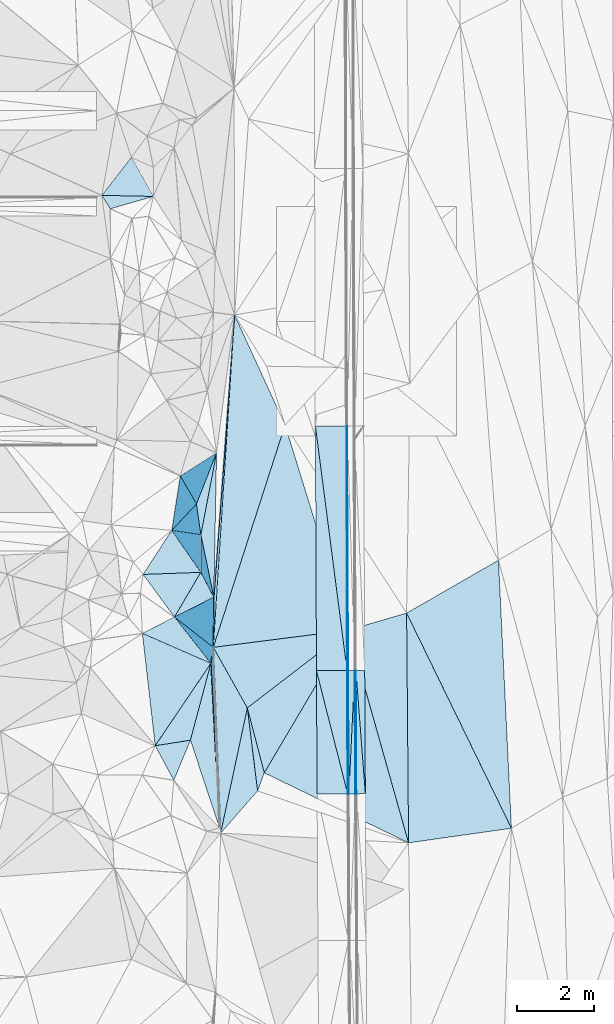
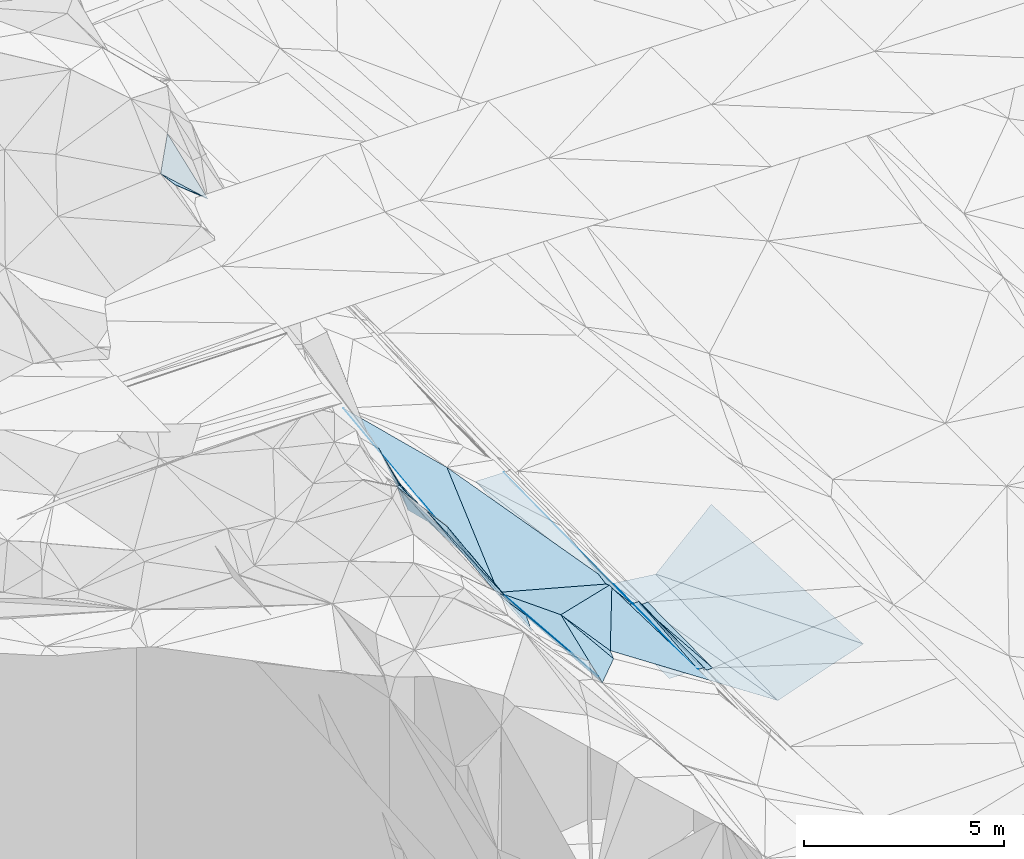
# One storey, part 63 of 275: 46 plates.
"""IFC2X3 building model written with IfcOpenShell, lengths in millimetres."""

from ifc_helpers import new_model, si_unit, frame, origin_with_axes, place, context, subcontext, project, spatial, polyline, outline, extrude, material, type_object, element, save


model = new_model("IFC2X3")

# Units and contexts
model_context = context("Model", 3, precision=1e-05, world=origin_with_axes())
body_context = subcontext(model_context, "Body", "Model", "MODEL_VIEW")
ifc_project = project(units=[si_unit("LENGTHUNIT", "METRE", prefix="MILLI"), si_unit("AREAUNIT", "SQUARE_METRE"), si_unit("VOLUMEUNIT", "CUBIC_METRE"), si_unit("MASSUNIT", "GRAM", prefix="KILO"), si_unit("TIMEUNIT", "SECOND"), si_unit("PLANEANGLEUNIT", "RADIAN"), si_unit("SOLIDANGLEUNIT", "STERADIAN"), si_unit("THERMODYNAMICTEMPERATUREUNIT", "DEGREE_CELSIUS"), si_unit("LUMINOUSINTENSITYUNIT", "LUMEN")], contexts=[model_context])

# Site, building, storey
site_placement = place(None, origin_with_axes())
site = spatial("IfcSite", under=ifc_project, at=site_placement, CompositionType="ELEMENT")
building_placement = place(site_placement, origin_with_axes())
building = spatial("IfcBuilding", under=site, at=building_placement, Name="Undefined", CompositionType="ELEMENT")
storey_placement = place(building_placement, origin_with_axes())
storey = spatial("IfcBuildingStorey", under=building, at=storey_placement, Name="Undefined", CompositionType="ELEMENT", Elevation=0.0)

# Plates
ifc_material = material()
plate_type_1 = type_object("IfcPlateType", PredefinedType="NOTDEFINED")
plate_1_placement = place(storey_placement, frame((-94041.2478735772, 50948.7305585253, 41968.9917380828), z_axis=(-0.970144857426459, -0.000212112947850965, -0.242526102960264), x_axis=(-0.0142838621161237, 0.998313705221828, 0.0562647069601703)))
element("IfcPlate", 1, at=plate_1_placement, inside=storey, type_object=plate_type_1, material=ifc_material, Name="00_PR", context=body_context, shape_type="SweptSolid", body=[
    extrude(outline(polyline([(0.0, 0.0), (3227.333984375, -1.0986695997417e-08), (3220.42529296875, 123.500061035156), (0.0, 0.0)])), frame((-8.85201319254618e-08, 2.18876761149539e-07, -0.5000001331573), z_axis=(0.0, 0.0, 1.0), x_axis=(1.0, 0.0, 0.0)), (0.0, 0.0, 1.0), 1.0),
])
plate_2_placement = place(storey_placement, frame((-94071.035261169, 50945.771579664, 42088.9925398327), z_axis=(-0.970544312702776, -0.000308208476193155, -0.240922481491106), x_axis=(-0.00505711011222381, 0.999804917063074, 0.019093282950109)))
element("IfcPlate", 2, at=plate_2_placement, inside=storey, type_object=plate_type_1, material=ifc_material, Name="00_PR", context=body_context, shape_type="SweptSolid", body=[
    extrude(outline(polyline([(0.0, 0.0), (3225.47998046875, -1.05428625829518e-08), (0.516522586345673, 123.676048278809), (0.0, 0.0)])), frame((-8.85201319254618e-08, 2.18876761149539e-07, -0.5000001331573), z_axis=(0.0, 0.0, 1.0), x_axis=(1.0, 0.0, 0.0)), (0.0, 0.0, 1.0), 1.0),
])
plate_type_2 = type_object("IfcPlateType", PredefinedType="NOTDEFINED")
plate_3_placement = place(storey_placement, frame((-94286.8693814352, 54169.6735547342, 42150.7981971723), z_axis=(-0.020087146616236, 0.0196603324347761, -0.999604910886982), x_axis=(0.000438543900374079, 0.99980671603672, 0.019655488981887)))
element("IfcPlate", 3, at=plate_3_placement, inside=storey, type_object=plate_type_2, material=ifc_material, Name="00_PR", context=body_context, shape_type="SweptSolid", body=[
    extrude(outline(polyline([(0.0, 0.0), (6386.56201171875, 4.8748916015029e-09), (0.145709604024887, 30.0053462982178), (0.0, 0.0)])), frame((-8.85201319254618e-08, 2.18876761149539e-07, -0.5000001331573), z_axis=(0.0, 0.0, 1.0), x_axis=(1.0, 0.0, 0.0)), (0.0, 0.0, 1.0), 1.0),
])
plate_4_placement = place(storey_placement, frame((-94270.5574787857, 50944.7155366074, 42089.2131909046), z_axis=(-0.0200935656827994, 0.0189875293703551, -0.999617788130324), x_axis=(0.0042432388975566, 0.99981226276399, 0.0189059289750381)))
element("IfcPlate", 4, at=plate_4_placement, inside=storey, type_object=plate_type_2, material=ifc_material, Name="00_PR", context=body_context, shape_type="SweptSolid", body=[
    extrude(outline(polyline([(0.0, 0.0), (3225.70776367188, 6.12635631114244e-09), (0.275933593511581, 30.0052528381348), (0.0, 0.0)])), frame((-8.85201319254618e-08, 2.18876761149539e-07, -0.5000001331573), z_axis=(0.0, 0.0, 1.0), x_axis=(1.0, 0.0, 0.0)), (0.0, 0.0, 1.0), 1.0),
])
plate_5_placement = place(storey_placement, frame((-94256.8700281877, 54169.817593453, 42150.1981918576), z_axis=(-0.0200835313920185, 0.0189874969806564, -0.999617990396949), x_axis=(-0.00424323889120028, -0.999812262764378, -0.0189059289559082)))
element("IfcPlate", 5, at=plate_5_placement, inside=storey, type_object=plate_type_2, material=ifc_material, Name="00_PR", context=body_context, shape_type="SweptSolid", body=[
    extrude(outline(polyline([(0.0, 0.0), (3225.70776367188, 6.12635631114244e-09), (0.260298550128937, 30.0045719146729), (0.0, 0.0)])), frame((-8.85201319254618e-08, 2.18876761149539e-07, -0.5000001331573), z_axis=(0.0, 0.0, 1.0), x_axis=(1.0, 0.0, 0.0)), (0.0, 0.0, 1.0), 1.0),
])
plate_type_3 = type_object("IfcPlateType", PredefinedType="NOTDEFINED")
plate_6_placement = place(storey_placement, frame((-95086.8597378606, 54165.8420910092, 42166.7981906724), z_axis=(-0.0200835313920185, 0.0189874969806564, -0.999617990396949), x_axis=(0.999788595128482, 0.00478795512433711, -0.0199960130211749)))
element("IfcPlate", 6, at=plate_6_placement, inside=storey, type_object=plate_type_3, material=ifc_material, Name="00_PR", context=body_context, shape_type="SweptSolid", body=[
    extrude(outline(polyline([(0.0, 0.0), (800.159484863281, -4.0818122215569e-09), (802.258483886719, 3225.58618164063), (0.0, 0.0)])), frame((-8.85201319254618e-08, 2.18876761149539e-07, -0.5000001331573), z_axis=(0.0, 0.0, 1.0), x_axis=(1.0, 0.0, 0.0)), (0.0, 0.0, 1.0), 1.0),
])
plate_7_placement = place(storey_placement, frame((-95114.0626587385, 60551.9062229557, 42292.9291968387), z_axis=(-0.020065563650007, 0.019660330856377, -0.99960534439649), x_axis=(0.99979310769204, 0.00372851110529092, -0.0199960000107533)))
element("IfcPlate", 7, at=plate_7_placement, inside=storey, type_object=plate_type_3, material=ifc_material, Name="00_PR", context=body_context, shape_type="SweptSolid", body=[
    extrude(outline(polyline([(0.0, 0.0), (800.160034179688, -7.8580342233181e-10), (806.067993164063, 6386.51708984375), (0.0, 0.0)])), frame((-8.85201319254618e-08, 2.18876761149539e-07, -0.5000001331573), z_axis=(0.0, 0.0, 1.0), x_axis=(1.0, 0.0, 0.0)), (0.0, 0.0, 1.0), 1.0),
])
plate_8_placement = place(storey_placement, frame((-94286.8693814352, 54169.6735547342, 42150.7981971723), z_axis=(-0.0200864802887268, 0.0196576115205439, -0.999604977788185), x_axis=(-0.999788595128673, -0.00478795510259425, 0.0199960130168507)))
element("IfcPlate", 8, at=plate_8_placement, inside=storey, type_object=plate_type_3, material=ifc_material, Name="00_PR", context=body_context, shape_type="SweptSolid", body=[
    extrude(outline(polyline([(0.0, 0.0), (800.159484863281, -4.0818122215569e-09), (799.302612304688, 6387.3671875), (0.0, 0.0)])), frame((-8.85201319254618e-08, 2.18876761149539e-07, -0.5000001331573), z_axis=(0.0, 0.0, 1.0), x_axis=(1.0, 0.0, 0.0)), (0.0, 0.0, 1.0), 1.0),
])
plate_9_placement = place(storey_placement, frame((-94270.5574787857, 50944.7155366074, 42089.2131909046), z_axis=(-0.0200937685935503, 0.018984898210887, -0.9996178340264), x_axis=(-0.99978587787653, -0.00532522509258222, 0.0199960090110697)))
element("IfcPlate", 9, at=plate_9_placement, inside=storey, type_object=plate_type_3, material=ifc_material, Name="00_PR", context=body_context, shape_type="SweptSolid", body=[
    extrude(outline(polyline([(0.0, 0.0), (800.15966796875, 1.0113581083715e-09), (800.525634765625, 3226.0166015625), (0.0, 0.0)])), frame((-8.85201319254618e-08, 2.18876761149539e-07, -0.5000001331573), z_axis=(0.0, 0.0, 1.0), x_axis=(1.0, 0.0, 0.0)), (0.0, 0.0, 1.0), 1.0),
])
plate_type_4 = type_object("IfcPlateType", PredefinedType="NOTDEFINED")
plate_10_placement = place(storey_placement, frame((-94056.84665461, 54170.9040629305, 42030.1983585212), z_axis=(0.0325038050928292, 0.0193184689417992, -0.999284894017833), x_axis=(0.999459808725716, 0.00423071511506999, 0.0325912839816308)))
element("IfcPlate", 10, at=plate_10_placement, inside=storey, type_object=plate_type_4, material=ifc_material, Name="00_PR", context=body_context, shape_type="SweptSolid", body=[
    extrude(outline(polyline([(0.0, 0.0), (230.12287902832, -1.17870513349772e-09), (230.761566162109, 3213.30981445313), (0.0, 0.0)])), frame((-8.85201319254618e-08, 2.18876761149539e-07, -0.5000001331573), z_axis=(0.0, 0.0, 1.0), x_axis=(1.0, 0.0, 0.0)), (0.0, 0.0, 1.0), 1.0),
])
plate_11_placement = place(storey_placement, frame((-94056.8470525321, 54170.9040306075, 42030.1983445947), z_axis=(0.0317122800381576, 0.0192582290780445, -0.999311488930033), x_axis=(0.0764359521383084, -0.996933172121253, -0.0167867669599003)))
element("IfcPlate", 11, at=plate_11_placement, inside=storey, type_object=plate_type_4, material=ifc_material, Name="00_PR", context=body_context, shape_type="SweptSolid", body=[
    extrude(outline(polyline([(0.0, 0.0), (3221.58520507813, -6.18456397205591e-09), (3214.54638671875, 230.397048950195), (0.0, 0.0)])), frame((-8.85201319254618e-08, 2.18876761149539e-07, -0.5000001331573), z_axis=(0.0, 0.0, 1.0), x_axis=(1.0, 0.0, 0.0)), (0.0, 0.0, 1.0), 1.0),
])
plate_type_5 = type_object("IfcPlateType", PredefinedType="NOTDEFINED")
plate_12_placement = place(storey_placement, frame((-94240.5473874211, 50944.8755996114, 42088.6130914289), z_axis=(-9.14532402907773e-05, 0.0190925236186178, -0.999817716975538), x_axis=(-0.00505711011222381, 0.999804917063074, 0.019093282950109)))
element("IfcPlate", 12, at=plate_12_placement, inside=storey, type_object=plate_type_5, material=ifc_material, Name="00_PR", context=body_context, shape_type="SweptSolid", body=[
    extrude(outline(polyline([(0.0, 0.0), (3225.5712890625, 6.81029632687569e-09), (3225.52563476563, 170.000335693359), (0.0, 0.0)])), frame((-8.85201319254618e-08, 2.18876761149539e-07, -0.5000001331573), z_axis=(0.0, 0.0, 1.0), x_axis=(1.0, 0.0, 0.0)), (0.0, 0.0, 1.0), 1.0),
])
plate_13_placement = place(storey_placement, frame((-94086.861647268, 54170.6319423128, 42150.1980923486), z_axis=(-0.000101724851935278, 0.0190939669352112, -0.99981768842061), x_axis=(0.00505711010990044, -0.999804917062819, -0.0190932829640522)))
element("IfcPlate", 13, at=plate_13_placement, inside=storey, type_object=plate_type_5, material=ifc_material, Name="00_PR", context=body_context, shape_type="SweptSolid", body=[
    extrude(outline(polyline([(0.0, 0.0), (3225.47998046875, -1.05428625829518e-08), (3225.52563476563, 169.999755859375), (0.0, 0.0)])), frame((-8.85201319254618e-08, 2.18876761149539e-07, -0.5000001331573), z_axis=(0.0, 0.0, 1.0), x_axis=(1.0, 0.0, 0.0)), (0.0, 0.0, 1.0), 1.0),
])
plate_type_6 = type_object("IfcPlateType", PredefinedType="NOTDEFINED")
plate_14_placement = place(storey_placement, frame((-97619.1957707841, 50063.499972178, 43599.6789144039), z_axis=(-0.764987449668679, -0.0492397289156156, -0.642160144314272), x_axis=(-0.301722386218934, 0.908287838968304, 0.289787513941925)))
element("IfcPlate", 14, at=plate_14_placement, inside=storey, type_object=plate_type_6, material=ifc_material, Name="00", context=body_context, shape_type="SweptSolid", body=[
    extrude(outline(polyline([(0.0, 0.0), (2519.08715820313, 9.29867383092642e-09), (3952.26513671875, 1698.38195800781), (0.0, 0.0)])), frame((-8.85201319254618e-08, 2.18876761149539e-07, -0.5000001331573), z_axis=(0.0, 0.0, 1.0), x_axis=(1.0, 0.0, 0.0)), (0.0, 0.0, 1.0), 1.0),
])
plate_type_7 = type_object("IfcPlateType", PredefinedType="NOTDEFINED")
plate_15_placement = place(storey_placement, frame((-97845.3021135875, 54358.8622632258, 43539.6722890846), z_axis=(-0.753071464707979, -0.0576242265461258, -0.655410419170721), x_axis=(-0.240273150917753, -0.903268735191453, 0.355491779052185)))
element("IfcPlate", 15, at=plate_15_placement, inside=storey, type_object=plate_type_7, material=ifc_material, Name="00", context=body_context, shape_type="SweptSolid", body=[
    extrude(outline(polyline([(0.0, 0.0), (2222.27368164063, -8.23638401925564e-09), (2954.181640625, 1215.24096679688), (0.0, 0.0)])), frame((-8.85201319254618e-08, 2.18876761149539e-07, -0.5000001331573), z_axis=(0.0, 0.0, 1.0), x_axis=(1.0, 0.0, 0.0)), (0.0, 0.0, 1.0), 1.0),
])
plate_type_8 = type_object("IfcPlateType", PredefinedType="NOTDEFINED")
plate_16_placement = place(storey_placement, frame((-97589.7876435885, 49923.3579279988, 43470.5213036737), z_axis=(-0.288374058145688, 0.0172401610551849, -0.957362616481017), x_axis=(0.208147440378868, 0.977057001186715, -0.045102765943434)))
element("IfcPlate", 16, at=plate_16_placement, inside=storey, type_object=plate_type_8, material=ifc_material, Name="00", context=body_context, shape_type="SweptSolid", body=[
    extrude(outline(polyline([(0.0, 0.0), (3347.90991210938, 2.95403879135847e-09), (1292.72326660156, 745.390930175781), (0.0, 0.0)])), frame((-8.85201319254618e-08, 2.18876761149539e-07, -0.5000001331573), z_axis=(0.0, 0.0, 1.0), x_axis=(1.0, 0.0, 0.0)), (0.0, 0.0, 1.0), 1.0),
])
plate_type_9 = type_object("IfcPlateType", PredefinedType="NOTDEFINED")
plate_17_placement = place(storey_placement, frame((-97781.8107361733, 54777.2097573126, 43352.5234270302), z_axis=(-0.300480631491925, 0.0358031453393913, -0.953115693335295), x_axis=(0.0638375603417415, 0.997809359253404, 0.0173565110527927)))
element("IfcPlate", 17, at=plate_17_placement, inside=storey, type_object=plate_type_9, material=ifc_material, Name="00", context=body_context, shape_type="SweptSolid", body=[
    extrude(outline(polyline([(0.0, 0.0), (8699.9052734375, 9.42964106798172e-09), (5907.5595703125, 1574.05517578125), (0.0, 0.0)])), frame((-8.85201319254618e-08, 2.18876761149539e-07, -0.5000001331573), z_axis=(0.0, 0.0, 1.0), x_axis=(1.0, 0.0, 0.0)), (0.0, 0.0, 1.0), 1.0),
])
plate_type_10 = type_object("IfcPlateType", PredefinedType="NOTDEFINED")
plate_18_placement = place(storey_placement, frame((-98108.7437218397, 56735.2686741272, 44049.7539654565), z_axis=(-0.863810252047945, -0.108218220705728, -0.492057583179196), x_axis=(-0.44027926915805, 0.636926619825427, 0.632833821873807)))
element("IfcPlate", 18, at=plate_18_placement, inside=storey, type_object=plate_type_10, material=ifc_material, Name="00", context=body_context, shape_type="SweptSolid", body=[
    extrude(outline(polyline([(0.0, 0.0), (1722.4111328125, -2.03726813197136e-10), (487.223999023438, 883.749267578125), (0.0, 0.0)])), frame((-8.85201319254618e-08, 2.18876761149539e-07, -0.5000001331573), z_axis=(0.0, 0.0, 1.0), x_axis=(1.0, 0.0, 0.0)), (0.0, 0.0, 1.0), 1.0),
])
plate_type_11 = type_object("IfcPlateType", PredefinedType="NOTDEFINED")
plate_19_placement = place(storey_placement, frame((-97782.1521804794, 54777.1702439801, 43352.91225178), z_axis=(-0.983534899518548, -0.0431745983811892, -0.175485200184128), x_axis=(0.0395172212029287, -0.998923747664015, 0.0242844720197494)))
element("IfcPlate", 19, at=plate_19_placement, inside=storey, type_object=plate_type_11, material=ifc_material, Name="00", context=body_context, shape_type="SweptSolid", body=[
    extrude(outline(polyline([(0.0, 0.0), (4859.072265625, -1.7491402104497e-08), (4721.02783203125, 134.479461669922), (0.0, 0.0)])), frame((-8.85201319254618e-08, 2.18876761149539e-07, -0.5000001331573), z_axis=(0.0, 0.0, 1.0), x_axis=(1.0, 0.0, 0.0)), (0.0, 0.0, 1.0), 1.0),
])
plate_type_12 = type_object("IfcPlateType", PredefinedType="NOTDEFINED")
plate_20_placement = place(storey_placement, frame((-97696.0473812489, 59858.6828216023, 43579.5032715729), z_axis=(-0.0140671744375118, -0.11343716241145, -0.993445582197325), x_axis=(-0.187210856905023, -0.975675481422134, 0.114058976010549)))
element("IfcPlate", 20, at=plate_20_placement, inside=storey, type_object=plate_type_12, material=ifc_material, Name="00", context=body_context, shape_type="SweptSolid", body=[
    extrude(outline(polyline([(0.0, 0.0), (2191.8486328125, 1.33877620100975e-09), (1420.12548828125, 263.331665039063), (0.0, 0.0)])), frame((-8.85201319254618e-08, 2.18876761149539e-07, -0.5000001331573), z_axis=(0.0, 0.0, 1.0), x_axis=(1.0, 0.0, 0.0)), (0.0, 0.0, 1.0), 1.0),
])
plate_21_placement = place(storey_placement, frame((-96624.146918518, 51028.1775527761, 43199.5602682648), z_axis=(-0.475908435572073, -0.0103533485118151, -0.879433891276619), x_axis=(-0.122988558686484, 0.990888936201074, 0.0548901680314859)))
element("IfcPlate", 21, at=plate_21_placement, inside=storey, type_object=plate_type_12, material=ifc_material, Name="00", context=body_context, shape_type="SweptSolid", body=[
    extrude(outline(polyline([(0.0, 0.0), (2186.18383789063, -7.42147676646709e-10), (439.533020019531, 262.508514404297), (0.0, 0.0)])), frame((-8.85201319254618e-08, 2.18876761149539e-07, -0.5000001331573), z_axis=(0.0, 0.0, 1.0), x_axis=(1.0, 0.0, 0.0)), (0.0, 0.0, 1.0), 1.0),
])
plate_type_13 = type_object("IfcPlateType", PredefinedType="NOTDEFINED")
plate_22_placement = place(storey_placement, frame((-97845.3243523275, 54358.9804197223, 43539.7119039261), z_axis=(-0.797550101736951, 0.178688497787806, -0.57618074939876), x_axis=(-0.534382803162085, 0.23390555092117, 0.812233471935808)))
element("IfcPlate", 22, at=plate_22_placement, inside=storey, type_object=plate_type_13, material=ifc_material, Name="00", context=body_context, shape_type="SweptSolid", body=[
    extrude(outline(polyline([(0.0, 0.0), (3348.79077148438, 1.12449924927205e-08), (2163.1689453125, 735.731262207031), (0.0, 0.0)])), frame((-8.85201319254618e-08, 2.18876761149539e-07, -0.5000001331573), z_axis=(0.0, 0.0, 1.0), x_axis=(1.0, 0.0, 0.0)), (0.0, 0.0, 1.0), 1.0),
])
plate_type_14 = type_object("IfcPlateType", PredefinedType="NOTDEFINED")
plate_23_placement = place(storey_placement, frame((-99344.2665062792, 66554.4409793796, 48739.7041192764), z_axis=(-0.523474264175147, 0.613032273131899, -0.591748364463329), x_axis=(-0.740921059733155, 0.0154243247931671, 0.671414978570313)))
element("IfcPlate", 23, at=plate_23_placement, inside=storey, type_object=plate_type_14, material=ifc_material, Name="00", context=body_context, shape_type="SweptSolid", body=[
    extrude(outline(polyline([(0.0, 0.0), (1817.05810546875, -1.32386048790067e-08), (1494.9990234375, 1269.20361328125), (0.0, 0.0)])), frame((-8.85201319254618e-08, 2.18876761149539e-07, -0.5000001331573), z_axis=(0.0, 0.0, 1.0), x_axis=(1.0, 0.0, 0.0)), (0.0, 0.0, 1.0), 1.0),
])
plate_type_15 = type_object("IfcPlateType", PredefinedType="NOTDEFINED")
plate_24_placement = place(storey_placement, frame((-100469.979595195, 66231.4437873825, 49749.6294627605), z_axis=(-0.671093818590625, 0.021500889977149, -0.741060590221639), x_axis=(-0.474998882297066, 0.754996805978761, 0.452057391022874)))
element("IfcPlate", 24, at=plate_24_placement, inside=storey, type_object=plate_type_15, material=ifc_material, Name="00", context=body_context, shape_type="SweptSolid", body=[
    extrude(outline(polyline([(0.0, 0.0), (464.542785644531, 8.73114913702011e-10), (-747.616821289063, 1353.65026855469), (0.0, 0.0)])), frame((-8.85201319254618e-08, 2.18876761149539e-07, -0.5000001331573), z_axis=(0.0, 0.0, 1.0), x_axis=(1.0, 0.0, 0.0)), (0.0, 0.0, 1.0), 1.0),
])
plate_type_16 = type_object("IfcPlateType", PredefinedType="NOTDEFINED")
plate_25_placement = place(storey_placement, frame((-97767.7364172808, 56087.8949552534, 43459.6211395034), z_axis=(-0.651574133181655, 0.0364447392700818, -0.757709000836146), x_axis=(-0.198491554278412, 0.955854622200097, 0.216663435075812)))
element("IfcPlate", 25, at=plate_25_placement, inside=storey, type_object=plate_type_16, material=ifc_material, Name="00", context=body_context, shape_type="SweptSolid", body=[
    extrude(outline(polyline([(0.0, 0.0), (1707.7177734375, 3.85625753551722e-09), (3616.22973632813, 1077.85974121094), (0.0, 0.0)])), frame((-8.85201319254618e-08, 2.18876761149539e-07, -0.5000001331573), z_axis=(0.0, 0.0, 1.0), x_axis=(1.0, 0.0, 0.0)), (0.0, 0.0, 1.0), 1.0),
])
plate_type_17 = type_object("IfcPlateType", PredefinedType="NOTDEFINED")
plate_26_placement = place(storey_placement, frame((-98642.9777640638, 59254.5288491423, 45319.8331359243), z_axis=(-0.9237689008145, 0.187840262650734, -0.333717026259184), x_axis=(0.23551325925698, -0.408488711013058, -0.881856268157711)))
element("IfcPlate", 26, at=plate_26_placement, inside=storey, type_object=plate_type_17, material=ifc_material, Name="00", context=body_context, shape_type="SweptSolid", body=[
    extrude(outline(polyline([(0.0, 0.0), (1791.67517089844, 9.76797309704125e-10), (686.84326171875, 1277.94616699219), (0.0, 0.0)])), frame((-8.85201319254618e-08, 2.18876761149539e-07, -0.5000001331573), z_axis=(0.0, 0.0, 1.0), x_axis=(1.0, 0.0, 0.0)), (0.0, 0.0, 1.0), 1.0),
])
plate_type_18 = type_object("IfcPlateType", PredefinedType="NOTDEFINED")
plate_27_placement = place(storey_placement, frame((-98106.807106262, 57720.1185536978, 43829.7586107317), z_axis=(-0.857835319073835, -0.176222417176294, -0.482767257624247), x_axis=(-0.500582258934883, 0.0738523158580916, 0.862533035588809)))
element("IfcPlate", 27, at=plate_27_placement, inside=storey, type_object=plate_type_18, material=ifc_material, Name="00", context=body_context, shape_type="SweptSolid", body=[
    extrude(outline(polyline([(0.0, 0.0), (1518.78234863281, -2.12457962334156e-09), (38.7810668945313, 814.491271972656), (0.0, 0.0)])), frame((-8.85201319254618e-08, 2.18876761149539e-07, -0.5000001331573), z_axis=(0.0, 0.0, 1.0), x_axis=(1.0, 0.0, 0.0)), (0.0, 0.0, 1.0), 1.0),
])
plate_type_19 = type_object("IfcPlateType", PredefinedType="NOTDEFINED")
plate_28_placement = place(storey_placement, frame((-97696.4792827328, 59858.8894873059, 43579.8133117681), z_axis=(-0.877872612513661, 0.299896226976729, -0.373365677645337), x_axis=(-0.36315170884924, -0.9251211451078, 0.11077771993641)))
element("IfcPlate", 28, at=plate_28_placement, inside=storey, type_object=plate_type_19, material=ifc_material, Name="00", context=body_context, shape_type="SweptSolid", body=[
    extrude(outline(polyline([(0.0, 0.0), (1444.33374023438, 2.3719621822238e-09), (1095.5224609375, 1757.39318847656), (0.0, 0.0)])), frame((-8.85201319254618e-08, 2.18876761149539e-07, -0.5000001331573), z_axis=(0.0, 0.0, 1.0), x_axis=(1.0, 0.0, 0.0)), (0.0, 0.0, 1.0), 1.0),
])
plate_type_20 = type_object("IfcPlateType", PredefinedType="NOTDEFINED")
plate_29_placement = place(storey_placement, frame((-98867.054432637, 57832.3917553855, 45139.7015873193), z_axis=(-0.801432441794667, 0.0389835528239967, -0.596813474921818), x_axis=(0.440279269156894, -0.636926619825563, -0.632833821874475)))
element("IfcPlate", 29, at=plate_29_placement, inside=storey, type_object=plate_type_20, material=ifc_material, Name="00", context=body_context, shape_type="SweptSolid", body=[
    extrude(outline(polyline([(0.0, 0.0), (1722.4111328125, -2.03726813197136e-10), (-185.031326293945, 1647.92700195313), (0.0, 0.0)])), frame((-8.85201319254618e-08, 2.18876761149539e-07, -0.5000001331573), z_axis=(0.0, 0.0, 1.0), x_axis=(1.0, 0.0, 0.0)), (0.0, 0.0, 1.0), 1.0),
])
plate_type_21 = type_object("IfcPlateType", PredefinedType="NOTDEFINED")
plate_30_placement = place(storey_placement, frame((-98108.7443408662, 56735.3236326324, 44049.7491507277), z_axis=(-0.865047556651814, 0.00169835252231776, -0.5016869943794), x_axis=(0.36268135616518, -0.688811368806975, -0.627695094844979)))
element("IfcPlate", 30, at=plate_30_placement, inside=storey, type_object=plate_type_21, material=ifc_material, Name="00", context=body_context, shape_type="SweptSolid", body=[
    extrude(outline(polyline([(0.0, 0.0), (939.94677734375, 2.74667399935424e-09), (-185.648803710938, 1786.62658691406), (0.0, 0.0)])), frame((-8.85201319254618e-08, 2.18876761149539e-07, -0.5000001331573), z_axis=(0.0, 0.0, 1.0), x_axis=(1.0, 0.0, 0.0)), (0.0, 0.0, 1.0), 1.0),
])
plate_type_22 = type_object("IfcPlateType", PredefinedType="NOTDEFINED")
plate_31_placement = place(storey_placement, frame((-97767.8619519911, 56087.8306659336, 43459.7897802084), z_axis=(-0.902635075806441, -0.0921416584968979, -0.420428156399332), x_axis=(-0.362681356168702, 0.688811368807507, 0.62769509484236)))
element("IfcPlate", 31, at=plate_31_placement, inside=storey, type_object=plate_type_22, material=ifc_material, Name="00", context=body_context, shape_type="SweptSolid", body=[
    extrude(outline(polyline([(0.0, 0.0), (939.94677734375, 2.74667399935424e-09), (1479.5517578125, 852.775756835938), (0.0, 0.0)])), frame((-8.85201319254618e-08, 2.18876761149539e-07, -0.5000001331573), z_axis=(0.0, 0.0, 1.0), x_axis=(1.0, 0.0, 0.0)), (0.0, 0.0, 1.0), 1.0),
])
plate_type_23 = type_object("IfcPlateType", PredefinedType="NOTDEFINED")
plate_32_placement = place(storey_placement, frame((-98795.3444876451, 55567.9376290583, 45229.7026099416), z_axis=(-0.792465081080224, -0.135089103620246, -0.594768887343305), x_axis=(-0.506933517383763, 0.688120619125273, 0.519142006090412)))
element("IfcPlate", 32, at=plate_32_placement, inside=storey, type_object=plate_type_23, material=ifc_material, Name="00", context=body_context, shape_type="SweptSolid", body=[
    extrude(outline(polyline([(0.0, 0.0), (1618.05444335938, -3.4233380574733e-09), (-157.411270141602, 1789.33557128906), (0.0, 0.0)])), frame((-8.85201319254618e-08, 2.18876761149539e-07, -0.5000001331573), z_axis=(0.0, 0.0, 1.0), x_axis=(1.0, 0.0, 0.0)), (0.0, 0.0, 1.0), 1.0),
])
plate_type_24 = type_object("IfcPlateType", PredefinedType="NOTDEFINED")
plate_33_placement = place(storey_placement, frame((-97782.095423489, 54777.216576459, 43352.7547291575), z_axis=(-0.870016721154178, 0.0495041304484479, -0.490530575989588), x_axis=(-0.44541665338475, 0.347622286070695, 0.825083481300234)))
element("IfcPlate", 33, at=plate_33_placement, inside=storey, type_object=plate_type_24, material=ifc_material, Name="00", context=body_context, shape_type="SweptSolid", body=[
    extrude(outline(polyline([(0.0, 0.0), (2274.92138671875, 3.63797880709171e-12), (537.560119628906, 1200.23999023438), (0.0, 0.0)])), frame((-8.85201319254618e-08, 2.18876761149539e-07, -0.5000001331573), z_axis=(0.0, 0.0, 1.0), x_axis=(1.0, 0.0, 0.0)), (0.0, 0.0, 1.0), 1.0),
])
plate_type_25 = type_object("IfcPlateType", PredefinedType="NOTDEFINED")
plate_34_placement = place(storey_placement, frame((-98795.3930361557, 55567.971454738, 45229.7740890366), z_axis=(-0.889561072500037, -0.0674404043217097, -0.451810679552297), x_axis=(0.445416653387725, -0.347622286068997, -0.825083481299343)))
element("IfcPlate", 34, at=plate_34_placement, inside=storey, type_object=plate_type_25, material=ifc_material, Name="00", context=body_context, shape_type="SweptSolid", body=[
    extrude(outline(polyline([(0.0, 0.0), (2274.92138671875, 3.63797880709171e-12), (2237.86206054688, 461.057067871094), (0.0, 0.0)])), frame((-8.85201319254618e-08, 2.18876761149539e-07, -0.5000001331573), z_axis=(0.0, 0.0, 1.0), x_axis=(1.0, 0.0, 0.0)), (0.0, 0.0, 1.0), 1.0),
])
plate_type_26 = type_object("IfcPlateType", PredefinedType="NOTDEFINED")
plate_35_placement = place(storey_placement, frame((-97226.6643616266, 63458.0687725782, 43503.6820042751), z_axis=(-0.769346970518552, 0.060283695351526, -0.635980436042407), x_axis=(-0.0638375607914314, -0.997809359225653, -0.0173565109942203)))
element("IfcPlate", 35, at=plate_35_placement, inside=storey, type_object=plate_type_26, material=ifc_material, Name="00", context=body_context, shape_type="SweptSolid", body=[
    extrude(outline(polyline([(0.0, 0.0), (8699.9052734375, 9.42964106798172e-09), (7389.32470703125, 109.205192565918), (0.0, 0.0)])), frame((-8.85201319254618e-08, 2.18876761149539e-07, -0.5000001331573), z_axis=(0.0, 0.0, 1.0), x_axis=(1.0, 0.0, 0.0)), (0.0, 0.0, 1.0), 1.0),
])
plate_type_27 = type_object("IfcPlateType", PredefinedType="NOTDEFINED")
plate_36_placement = place(storey_placement, frame((-98379.2582491303, 52351.6507683138, 44329.682646572), z_axis=(-0.759986900312981, 0.139930054237934, -0.634696377233741), x_axis=(-0.371988212734036, -0.894431961754087, 0.248226177869446)))
element("IfcPlate", 36, at=plate_36_placement, inside=storey, type_object=plate_type_27, material=ifc_material, Name="00", context=body_context, shape_type="SweptSolid", body=[
    extrude(outline(polyline([(0.0, 0.0), (1168.28930664063, -1.87719706445932e-09), (737.060546875, 1212.12280273438), (0.0, 0.0)])), frame((-8.85201319254618e-08, 2.18876761149539e-07, -0.5000001331573), z_axis=(0.0, 0.0, 1.0), x_axis=(1.0, 0.0, 0.0)), (0.0, 0.0, 1.0), 1.0),
])
plate_type_28 = type_object("IfcPlateType", PredefinedType="NOTDEFINED")
plate_37_placement = place(storey_placement, frame((-99299.479092406, 52207.2126044565, 45399.7188072481), z_axis=(-0.82386003745956, 0.0706380471567904, -0.562374345939613), x_axis=(-0.109009335183282, 0.95393291366067, 0.279515582888975)))
element("IfcPlate", 37, at=plate_37_placement, inside=storey, type_object=plate_type_28, material=ifc_material, Name="00", context=body_context, shape_type="SweptSolid", body=[
    extrude(outline(polyline([(0.0, 0.0), (3076.75146484375, 9.02218744158745e-10), (1374.17663574219, 2883.68481445313), (0.0, 0.0)])), frame((-8.85201319254618e-08, 2.18876761149539e-07, -0.5000001331573), z_axis=(0.0, 0.0, 1.0), x_axis=(1.0, 0.0, 0.0)), (0.0, 0.0, 1.0), 1.0),
])
plate_type_29 = type_object("IfcPlateType", PredefinedType="NOTDEFINED")
plate_38_placement = place(storey_placement, frame((-97782.1121406149, 54777.165080221, 43352.7873306372), z_axis=(-0.903456383274452, -0.0535000470335676, -0.425328471287842), x_axis=(0.0344800162020529, -0.9980361004067, 0.0522979040468514)))
element("IfcPlate", 38, at=plate_38_placement, inside=storey, type_object=plate_type_29, material=ifc_material, Name="00", context=body_context, shape_type="SweptSolid", body=[
    extrude(outline(polyline([(0.0, 0.0), (4722.9423828125, -1.07829691842198e-08), (425.077575683594, 182.362426757813), (0.0, 0.0)])), frame((-8.85201319254618e-08, 2.18876761149539e-07, -0.5000001331573), z_axis=(0.0, 0.0, 1.0), x_axis=(1.0, 0.0, 0.0)), (0.0, 0.0, 1.0), 1.0),
])
plate_type_30 = type_object("IfcPlateType", PredefinedType="NOTDEFINED")
plate_39_placement = place(storey_placement, frame((-94249.0535413374, 55227.0774300215, 42109.5281799137), z_axis=(-0.329435835174723, 0.0327232891627322, -0.943610733750472), x_axis=(0.912465682731065, 0.267874399584819, -0.309272830822892)))
element("IfcPlate", 39, at=plate_39_placement, inside=storey, type_object=plate_type_30, material=ifc_material, Name="00", context=body_context, shape_type="SweptSolid", body=[
    extrude(outline(polyline([(0.0, 0.0), (1661.96301269531, 5.54427970200777e-09), (170.813064575195, 5818.25146484375), (0.0, 0.0)])), frame((-8.85201319254618e-08, 2.18876761149539e-07, -0.5000001331573), z_axis=(0.0, 0.0, 1.0), x_axis=(1.0, 0.0, 0.0)), (0.0, 0.0, 1.0), 1.0),
])
plate_type_31 = type_object("IfcPlateType", PredefinedType="NOTDEFINED")
plate_40_placement = place(storey_placement, frame((-96892.995049545, 53194.4519585002, 43319.5464617993), z_axis=(-0.42096045100615, 0.00760031425267124, -0.90704715087583), x_axis=(0.745253311761508, 0.572946757568475, -0.341071127919493)))
element("IfcPlate", 40, at=plate_40_placement, inside=storey, type_object=plate_type_31, material=ifc_material, Name="00", context=body_context, shape_type="SweptSolid", body=[
    extrude(outline(polyline([(0.0, 0.0), (3547.64721679688, -8.96397978067398e-09), (-565.924377441406, 1673.14965820313), (0.0, 0.0)])), frame((-8.85201319254618e-08, 2.18876761149539e-07, -0.5000001331573), z_axis=(0.0, 0.0, 1.0), x_axis=(1.0, 0.0, 0.0)), (0.0, 0.0, 1.0), 1.0),
])
plate_type_32 = type_object("IfcPlateType", PredefinedType="NOTDEFINED")
plate_41_placement = place(storey_placement, frame((-97589.686575765, 49923.3354978108, 43470.5020324344), z_axis=(-0.0861522200302507, -0.0276191048298944, -0.995899081248826), x_axis=(-0.0395172215459343, 0.998923747651306, -0.0242844719843659)))
element("IfcPlate", 41, at=plate_41_placement, inside=storey, type_object=plate_type_32, material=ifc_material, Name="00", context=body_context, shape_type="SweptSolid", body=[
    extrude(outline(polyline([(0.0, 0.0), (4859.072265625, -1.7491402104497e-08), (3243.70727539063, 828.772338867188), (0.0, 0.0)])), frame((-8.85201319254618e-08, 2.18876761149539e-07, -0.5000001331573), z_axis=(0.0, 0.0, 1.0), x_axis=(1.0, 0.0, 0.0)), (0.0, 0.0, 1.0), 1.0),
])
plate_type_33 = type_object("IfcPlateType", PredefinedType="NOTDEFINED")
plate_42_placement = place(storey_placement, frame((-89994.6933226555, 50051.2155302187, 41923.5101201046), z_axis=(0.196574059067171, 0.0385678390283553, -0.979730147078541), x_axis=(-0.970089787791056, -0.137494875531042, -0.200052400201064)))
element("IfcPlate", 42, at=plate_42_placement, inside=storey, type_object=plate_type_33, material=ifc_material, Name="00", context=body_context, shape_type="SweptSolid", body=[
    extrude(outline(polyline([(0.0, 0.0), (2769.2744140625, 5.46424416825175e-09), (1948.48034667969, 5949.947265625), (0.0, 0.0)])), frame((-8.85201319254618e-08, 2.18876761149539e-07, -0.5000001331573), z_axis=(0.0, 0.0, 1.0), x_axis=(1.0, 0.0, 0.0)), (0.0, 0.0, 1.0), 1.0),
])
plate_type_34 = type_object("IfcPlateType", PredefinedType="NOTDEFINED")
plate_43_placement = place(storey_placement, frame((-89994.7062063648, 50051.2090952725, 41923.5075025984), z_axis=(0.170798395567408, 0.0257085885300551, -0.984970546030383), x_axis=(-0.437257854634101, 0.897808983101177, -0.0523889150833797)))
element("IfcPlate", 43, at=plate_43_placement, inside=storey, type_object=plate_type_34, material=ifc_material, Name="00", context=body_context, shape_type="SweptSolid", body=[
    extrude(outline(polyline([(0.0, 0.0), (6260.86669921875, 2.95622157864273e-08), (6427.04931640625, 2799.18823242188), (0.0, 0.0)])), frame((-8.85201319254618e-08, 2.18876761149539e-07, -0.5000001331573), z_axis=(0.0, 0.0, 1.0), x_axis=(1.0, 0.0, 0.0)), (0.0, 0.0, 1.0), 1.0),
])
plate_type_35 = type_object("IfcPlateType", PredefinedType="NOTDEFINED")
plate_44_placement = place(storey_placement, frame((-96449.5680014165, 51498.9634872812, 43099.5452377362), z_axis=(-0.415697104716159, 0.00384365298771211, -0.909494993643348), x_axis=(0.495509917333527, 0.839506628077837, -0.22293170083571)))
element("IfcPlate", 44, at=plate_44_placement, inside=storey, type_object=plate_type_35, material=ifc_material, Name="00", context=body_context, shape_type="SweptSolid", body=[
    extrude(outline(polyline([(0.0, 0.0), (4440.82177734375, 2.51748133450747e-09), (717.754516601563, 4474.37060546875), (0.0, 0.0)])), frame((-8.85201319254618e-08, 2.18876761149539e-07, -0.5000001331573), z_axis=(0.0, 0.0, 1.0), x_axis=(1.0, 0.0, 0.0)), (0.0, 0.0, 1.0), 1.0),
])
plate_type_36 = type_object("IfcPlateType", PredefinedType="NOTDEFINED")
plate_45_placement = place(storey_placement, frame((-95906.7564972112, 60584.270494299, 42979.5298550642), z_axis=(-0.336994949679235, 0.0484191706981507, -0.940260595685895), x_axis=(0.292111590586504, -0.944016814589218, -0.153307117962109)))
element("IfcPlate", 45, at=plate_45_placement, inside=storey, type_object=plate_type_36, material=ifc_material, Name="00", context=body_context, shape_type="SweptSolid", body=[
    extrude(outline(polyline([(0.0, 0.0), (5674.88330078125, -1.88447302207351e-08), (4877.04296875, 3686.64599609375), (0.0, 0.0)])), frame((-8.85201319254618e-08, 2.18876761149539e-07, -0.5000001331573), z_axis=(0.0, 0.0, 1.0), x_axis=(1.0, 0.0, 0.0)), (0.0, 0.0, 1.0), 1.0),
])
plate_type_37 = type_object("IfcPlateType", PredefinedType="NOTDEFINED")
plate_46_placement = place(storey_placement, frame((-96892.9397376417, 53194.370801303, 43319.531005771), z_axis=(-0.310316866313948, -0.154719030400411, -0.937958135586577), x_axis=(-0.489587079772716, 0.871764943997507, 0.0181761859764045)))
element("IfcPlate", 46, at=plate_46_placement, inside=storey, type_object=plate_type_37, material=ifc_material, Name="00", context=body_context, shape_type="SweptSolid", body=[
    extrude(outline(polyline([(0.0, 0.0), (1815.5625, 6.18456397205591e-09), (455.55029296875, 3518.27709960938), (0.0, 0.0)])), frame((-8.85201319254618e-08, 2.18876761149539e-07, -0.5000001331573), z_axis=(0.0, 0.0, 1.0), x_axis=(1.0, 0.0, 0.0)), (0.0, 0.0, 1.0), 1.0),
])

save(model, "model.ifc")
